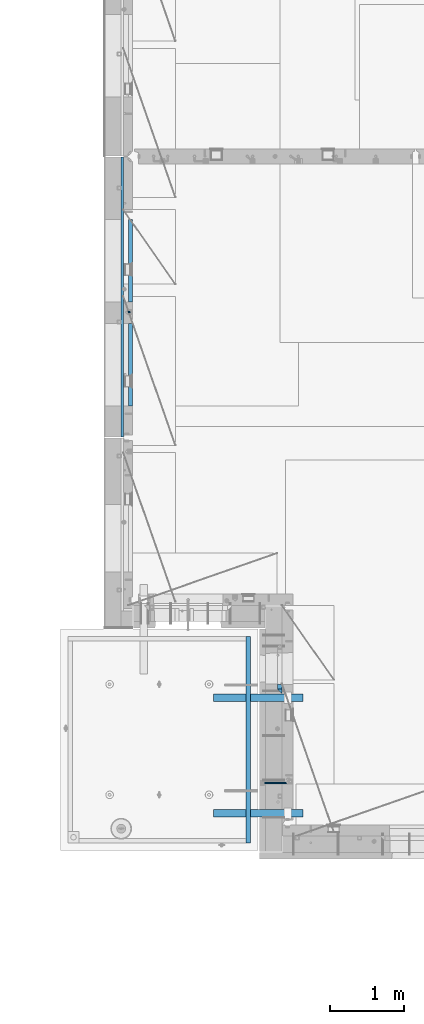
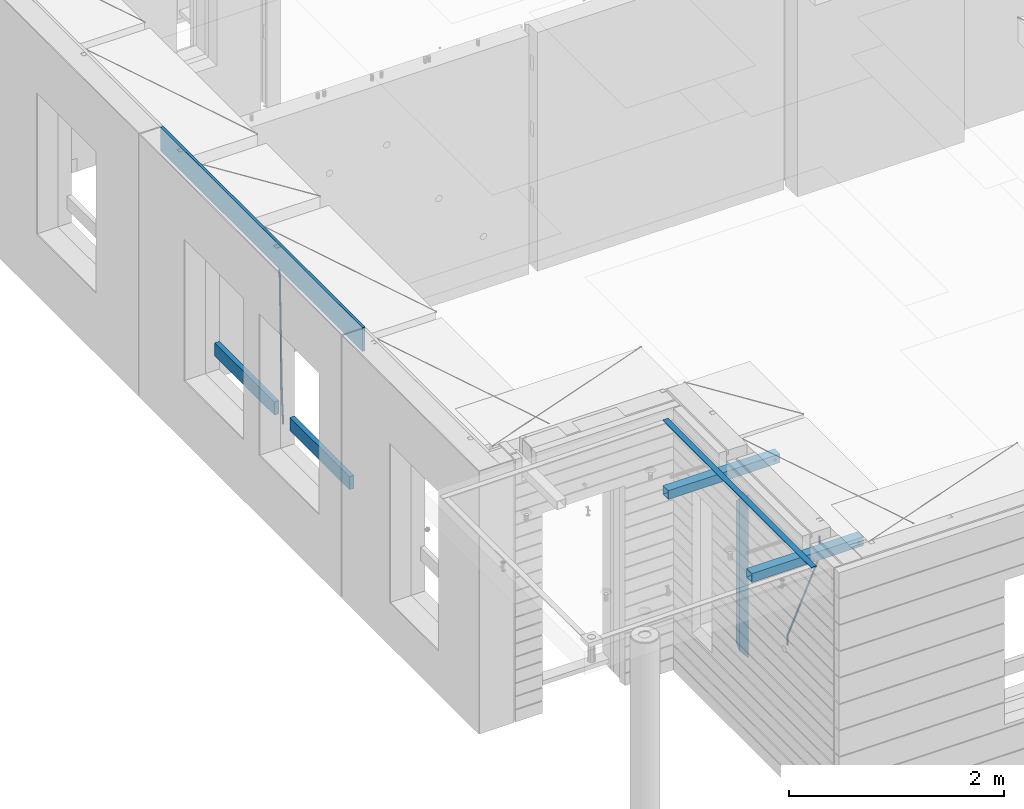
# One storey, part 93 of 350: 10 beams, 5 elements without a shape of their own.
"""IFC2X3 building model written with IfcOpenShell, lengths in millimetres."""

from ifc_helpers import new_model, si_unit, frame, origin_with_axes, place, context, subcontext, project, spatial, faceted_brep, material, type_object, element, aggregate, save


model = new_model("IFC2X3")

# Units and contexts
model_context = context("Model", 3, precision=1e-05, world=origin_with_axes())
body_context = subcontext(model_context, "Body", "Model", "MODEL_VIEW")
ifc_project = project(units=[si_unit("LENGTHUNIT", "METRE", prefix="MILLI"), si_unit("AREAUNIT", "SQUARE_METRE"), si_unit("VOLUMEUNIT", "CUBIC_METRE"), si_unit("MASSUNIT", "GRAM", prefix="KILO"), si_unit("TIMEUNIT", "SECOND"), si_unit("PLANEANGLEUNIT", "RADIAN"), si_unit("SOLIDANGLEUNIT", "STERADIAN"), si_unit("THERMODYNAMICTEMPERATUREUNIT", "DEGREE_CELSIUS"), si_unit("LUMINOUSINTENSITYUNIT", "LUMEN")], contexts=[model_context])

# Site, building, storey
site_placement = place(None, origin_with_axes())
site = spatial("IfcSite", under=ifc_project, at=site_placement, CompositionType="ELEMENT")
building_placement = place(site_placement, origin_with_axes())
building = spatial("IfcBuilding", under=site, at=building_placement, CompositionType="ELEMENT")
storey_placement = place(building_placement, origin_with_axes())
storey = spatial("IfcBuildingStorey", under=building, at=storey_placement, Name="2", CompositionType="ELEMENT", Elevation=0.0)

# Assembly, beam
assembly_1_placement = place(storey_placement, origin_with_axes())
assembly_1 = element("IfcElementAssembly", 1, at=assembly_1_placement, inside=storey, AssemblyPlace="NOTDEFINED", PredefinedType="REINFORCEMENT_UNIT")
ifc_material_1 = material()
beam_type_1 = type_object("IfcBeamType", Name="D20", PredefinedType="NOTDEFINED")
beam_1_placement = place(assembly_1_placement, frame((7964.99984877319, 14888.5021362169, 85590.0), z_axis=(-0.999642804636942, -0.000205726999925762, -0.0267249099902983), x_axis=(-0.0267249099948371, 4.30000201934385e-08, 0.999642825806181)))
beam_1 = element("IfcBeam", 2, at=beam_1_placement, type_object=beam_type_1, material=ifc_material_1, Name="JM20", ObjectType="D20", context=body_context, shape_type="Brep", body=[
    faceted_brep([(0.0, -10.0, 0.0), (-4.19531716033816e-08, -7.07106781186667, -7.07106781187031), (60.4266690400545, -7.0710677960451, -7.07106780570757), (60.4266690441291, -9.99999998418934, 6.15546014159918e-09), (0.0, 0.0, -10.0), (60.426669036824, 1.58106558956206e-08, -9.99999999384454), (4.196772351861e-08, 7.07106781186303, -7.07106781186667), (60.4266690363438, 7.07106782768096, -7.07106780570757), (0.0, 10.0, 0.0), (60.4266690388904, 10.0000000158179, 6.15182216279209e-09), (4.196772351861e-08, 7.07106781185939, 7.07106781185939), (60.4266690429649, 7.07106782768096, 7.07106781802577), (0.0, 0.0, 10.0), (60.4266690461809, 1.58179318532348e-08, 10.0000000061555), (-4.19531716033816e-08, -7.07106781187031, 7.07106781185939), (60.4266690466611, -7.07106779605238, 7.07106781802213), (61.0378400410118, -7.07106779588503, -7.07106780564936), (60.991799419251, -9.99999998403655, 6.21366780251265e-09), (61.0569027789461, 1.5985278878361e-08, -9.99999999378269), (61.0378209396877, 7.07106782784831, -7.07106780564936), (60.9917724058905, 10.0000000159635, 6.21366780251265e-09), (60.9457317841297, 7.07106782781193, 7.0710678180767), (60.9266690461809, 1.59488990902901e-08, 10.0000000062028), (60.9457508854539, -7.07106779591413, 7.0710678180767), (61.6489592143771, -7.07106614513759, -7.06310863441468), (61.5568818710308, -9.9999984576425, 0.00735959856683621), (61.6870830769039, 1.71821739058942e-06, -9.99179257185824), (61.6489210170112, 7.07106947854481, -7.06310888312146), (61.556827851804, 10.0000015422847, 0.00735924683976918), (61.4647505084577, 7.07106922979438, 7.07782747982128), (61.4266266459163, 1.36643211590126e-06, 10.0065114172685), (61.464788705809, -7.07106639389531, 7.07782772852806), (176.543135720174, -7.07075579406956, -5.56673531796696), (176.451058376813, -9.99968810657447, 1.50373291501455), (176.581259582701, 0.000312069292704109, -8.49541925541052), (176.543097522794, 7.07137982961285, -5.56673556667374), (176.451004357587, 10.00031189336, 1.50373256329476), (176.35892701424, 7.07137958085514, 8.57420079627263), (176.320803151699, 0.000311717507429421, 11.5028847337162), (176.358965211621, -7.07075604281999, 8.57420104497578), (177.098753836006, -7.07075429323595, -5.55949898843028), (176.98362511232, -9.99968666800123, 1.510669025065), (177.146421932586, 0.000313595905026887, -8.48805862247536), (177.098706077581, 7.07138133041735, -5.55949936166144), (176.983557571715, 10.0003133318824, 1.51066849724157), (176.868428848029, 7.07138095712435, 8.58083651073321), (176.820760751449, 0.000313067976094317, 11.5093961447819), (176.868476606425, -7.07075466652896, 8.58083688396073), (177.654312950661, -7.07075204110879, -5.54863964998367), (177.516135294456, -9.99968450931192, 1.52107783331303), (177.711524267797, 0.000315886711177882, -8.47701274570863), (177.654255632195, 7.07138358250813, -5.54864021007961), (177.516054233929, 10.0003154905207, 1.5210770412159), (177.377876577739, 7.0713830223176, 8.59079452451624), (177.320665260588, 0.000315094497636892, 11.5191676202448), (177.377933896176, -7.07075260129932, 8.59079508461218), (299.461778333818, -7.07025827596954, -3.16770791544877), (299.323600677439, -9.99919074416357, 3.90200956798253), (299.518989651391, 0.000809651852250681, -6.09608101123195), (299.46172101624, 7.07187734764193, -3.16770847554471), (299.323519618119, 10.0008092556727, 3.90200877589086), (299.18534196174, 7.07187678747687, 10.971726259324), (299.128130644167, 0.000808859655080596, 13.9000993551072), (299.185399279333, -7.07025883613824, 10.9717268194163), (300.005099199436, -7.07025607348805, -3.15708779472698), (299.971788958996, -9.99918809853989, 3.91467979818117), (300.018894160545, 0.00081167833377549, -6.08630953626562), (300.005085253739, 7.07187955030167, -3.15708750704471), (299.971753863239, 10.0008119014747, 3.91467990454839), (299.93844362146, 7.0718798403559, 10.9864468987271), (299.924648660366, 0.000812088532256894, 13.9156686402657), (299.938457567187, -7.07025578343564, 10.9864466110448), (300.548496018673, -7.07025720445017, -3.16258750978159), (300.620052478174, -9.9991894658433, 3.90811820064846), (300.518868553889, 0.000810637746326393, -6.09136977328126), (300.548525450897, 7.07187841925042, -3.16258766112878), (300.620094101629, 10.000810534113, 3.90811798661343), (300.69165056113, 7.07187827271991, 10.9788236970453), (300.721278025885, 0.000810430521596572, 13.907605960545), (300.691621128892, -7.07025735098068, 10.9788238483907), (1693.63216510082, -7.07315660432141, -17.2619766794614), (1693.70372156033, -10.0020888657109, -10.1912709690314), (1693.60253763606, -0.00208876212127507, -20.1907589429611), (1693.63219453306, 7.068979019381, -17.2619768308086), (1693.7037631838, 9.9979111342418, -10.1912711830664), (1693.77531964328, 7.06897887284867, -3.12056547263455), (1693.80494710806, -0.00208896934782388, -0.191783209134883), (1693.77529021105, -7.0731567508501, -3.12056532128736), (1694.29779868275, -7.07315798969103, -17.2687135518572), (1694.26743251897, -10.0020900389554, -10.1969762833342), (1694.34857500881, -0.00209031483609579, -20.1983095815103), (1694.39001741401, 7.06897744213711, -17.2696467503938), (1694.39784949942, 9.99790968965317, -10.1982960253627), (1694.36748333565, 7.06897764038877, -3.12655875683777), (1694.3167070096, -0.00209003446616407, -0.196962727188293), (1694.2752646044, -7.07315779143937, -3.125625558303), (1694.96335083364, -7.08183692566672, -17.2598557114488), (1694.83107451542, -10.0094400457037, -10.1894747662172), (1695.09452111425, -0.0118176043979474, -20.1883817771341), (1695.14774758583, 7.05909648594388, -17.259562111758), (1695.09185090323, 9.98885976961174, -10.1890595535533), (1694.95957458501, 7.0612566495729, -3.11867860832172), (1694.82840430441, -0.00876267169223865, -0.190152542638316), (1694.77517783281, -7.07967676203589, -3.11897220801256), (1716.74088258609, -7.36582038739652, -16.9700183177756), (1716.60860626785, -10.2934235074299, -9.8996373725422), (1716.87205286669, -0.295801066125932, -19.898544383459), (1716.92527933829, 6.77511302421226, -16.9697247180848), (1716.86938265568, 9.70487630788193, -9.89922215988008), (1716.73710633747, 6.77727318784673, -2.82884121464849), (1716.60593605686, -0.292746133423861, 0.0996848510367272), (1716.55270958526, -7.36366022376751, -2.82913481433934), (1717.37632925155, -7.37410674169405, -16.9615611515819), (1717.2686961548, -10.302031214369, -9.89085222946233), (1717.45037731848, -0.30334253509136, -19.8908474573927), (1717.44746400231, 6.76830362954752, -16.96277495703), (1717.36929588411, 9.6983573372836, -9.89256880959147), (1717.26166278738, 6.77043286460685, -2.82185988747187), (1717.18761472043, -0.300331341994024, 0.107426418340765), (1717.1905280366, -7.3719775066329, -2.82064608202199), (1718.0118297398, -7.37223067542982, -16.9532990407679), (1717.92884180055, -10.3000626540106, -9.8822625771154), (1718.02875100763, -0.301644694996867, -19.8833453418993), (1717.96969335481, 6.76984191386691, -16.9560200956876), (1717.86925195342, 9.69984820183527, -9.88611072988533), (1717.78626401415, 6.77201622325447, -2.81507426623284), (1717.76934274634, -0.298569757178484, 0.114972034898528), (1717.82840039914, -7.37005636604226, -2.81235321131317), (1818.03261514839, -7.07396855575644, -15.6559248891263), (1817.94962720915, -10.0018005343409, -8.58488842547376), (1818.04953641623, -0.00338257532712305, -18.5859711902594), (1817.99047876342, 7.06810403353848, -15.6586459440477), (1817.89003736203, 9.99811032150683, -8.58873657824552), (1817.80704942276, 7.07027834292421, -1.51770011459121), (1817.79012815493, -0.00030763750692131, 1.41234618654016), (1817.84918580775, -7.07179424637252, -1.51497905967153)], [[[0, 1, 2, 3]], [[1, 4, 5, 2]], [[4, 6, 7, 5]], [[6, 8, 9, 7]], [[8, 10, 11, 9]], [[10, 12, 13, 11]], [[12, 14, 15, 13]], [[14, 0, 3, 15]], [[14, 12, 10, 8, 6, 4, 1, 0]], [[3, 2, 16, 17]], [[2, 5, 18, 16]], [[5, 7, 19, 18]], [[7, 9, 20, 19]], [[9, 11, 21, 20]], [[11, 13, 22, 21]], [[13, 15, 23, 22]], [[15, 3, 17, 23]], [[17, 16, 24, 25]], [[16, 18, 26, 24]], [[18, 19, 27, 26]], [[19, 20, 28, 27]], [[20, 21, 29, 28]], [[21, 22, 30, 29]], [[22, 23, 31, 30]], [[23, 17, 25, 31]], [[25, 24, 32, 33]], [[24, 26, 34, 32]], [[26, 27, 35, 34]], [[27, 28, 36, 35]], [[28, 29, 37, 36]], [[29, 30, 38, 37]], [[30, 31, 39, 38]], [[31, 25, 33, 39]], [[33, 32, 40, 41]], [[32, 34, 42, 40]], [[34, 35, 43, 42]], [[35, 36, 44, 43]], [[36, 37, 45, 44]], [[37, 38, 46, 45]], [[38, 39, 47, 46]], [[39, 33, 41, 47]], [[41, 40, 48, 49]], [[40, 42, 50, 48]], [[42, 43, 51, 50]], [[43, 44, 52, 51]], [[44, 45, 53, 52]], [[45, 46, 54, 53]], [[46, 47, 55, 54]], [[47, 41, 49, 55]], [[49, 48, 56, 57]], [[48, 50, 58, 56]], [[50, 51, 59, 58]], [[51, 52, 60, 59]], [[52, 53, 61, 60]], [[53, 54, 62, 61]], [[54, 55, 63, 62]], [[55, 49, 57, 63]], [[57, 56, 64, 65]], [[56, 58, 66, 64]], [[58, 59, 67, 66]], [[59, 60, 68, 67]], [[60, 61, 69, 68]], [[61, 62, 70, 69]], [[62, 63, 71, 70]], [[63, 57, 65, 71]], [[65, 64, 72, 73]], [[64, 66, 74, 72]], [[66, 67, 75, 74]], [[67, 68, 76, 75]], [[68, 69, 77, 76]], [[69, 70, 78, 77]], [[70, 71, 79, 78]], [[71, 65, 73, 79]], [[73, 72, 80, 81]], [[72, 74, 82, 80]], [[74, 75, 83, 82]], [[75, 76, 84, 83]], [[76, 77, 85, 84]], [[77, 78, 86, 85]], [[78, 79, 87, 86]], [[79, 73, 81, 87]], [[81, 80, 88, 89]], [[80, 82, 90, 88]], [[82, 83, 91, 90]], [[83, 84, 92, 91]], [[84, 85, 93, 92]], [[85, 86, 94, 93]], [[86, 87, 95, 94]], [[87, 81, 89, 95]], [[89, 88, 96, 97]], [[88, 90, 98, 96]], [[90, 91, 99, 98]], [[91, 92, 100, 99]], [[92, 93, 101, 100]], [[93, 94, 102, 101]], [[94, 95, 103, 102]], [[95, 89, 97, 103]], [[97, 96, 104, 105]], [[96, 98, 106, 104]], [[98, 99, 107, 106]], [[99, 100, 108, 107]], [[100, 101, 109, 108]], [[101, 102, 110, 109]], [[102, 103, 111, 110]], [[103, 97, 105, 111]], [[105, 104, 112, 113]], [[104, 106, 114, 112]], [[106, 107, 115, 114]], [[107, 108, 116, 115]], [[108, 109, 117, 116]], [[109, 110, 118, 117]], [[110, 111, 119, 118]], [[111, 105, 113, 119]], [[113, 112, 120, 121]], [[112, 114, 122, 120]], [[114, 115, 123, 122]], [[115, 116, 124, 123]], [[116, 117, 125, 124]], [[117, 118, 126, 125]], [[118, 119, 127, 126]], [[119, 113, 121, 127]], [[121, 120, 128, 129]], [[120, 122, 130, 128]], [[122, 123, 131, 130]], [[123, 124, 132, 131]], [[124, 125, 133, 132]], [[125, 126, 134, 133]], [[126, 127, 135, 134]], [[127, 121, 129, 135]], [[130, 131, 132, 133, 134, 135, 129, 128]]]),
])

assembly_2_placement = place(storey_placement, origin_with_axes())
assembly_2 = element("IfcElementAssembly", 3, at=assembly_2_placement, inside=storey, AssemblyPlace="NOTDEFINED", PredefinedType="REINFORCEMENT_UNIT")
beam_2_placement = place(assembly_2_placement, frame((10084.9999999647, 8564.98166687309, 87407.5), z_axis=(-0.999999913638316, 0.000415599999849952, 0.0), x_axis=(0.0, 0.000121133999959918, -0.999999992663277)))
beam_2 = element("IfcBeam", 4, at=beam_2_placement, type_object=beam_type_1, material=ifc_material_1, Name="JM20", ObjectType="D20", context=body_context, shape_type="Brep", body=[
    faceted_brep([(-0.00060564729210455, -9.99999998165731, 0.0), (-0.000428079845733009, -7.07106779890455, -7.07106781186667), (119.575515501536, -7.07830994756296, -7.07106481604933), (119.575337932896, -10.0072421307195, -3.43332612828817e-06), (0.0, 0.0, -10.0), (119.575943836026, -0.00724214867295814, -9.99999700418266), (0.00042843479604926, 7.07106779888636, -7.07106781186303), (119.57637202373, 7.06382565022977, -7.07106481604933), (0.00060564729210455, 9.99999998166459, 3.63797880709171e-12), (119.576549238118, 9.99275783300072, 2.99581552098971e-06), (0.000428079845733009, 7.07106779890819, 7.07106781186667), (119.576371669405, 7.06382565024978, 7.07107080768037), (0.0, 0.0, 10.0), (119.57594333493, -0.00724214864203532, 10.0000029958155), (-0.000428434810601175, -7.07106779888272, 7.07106781186667), (119.575515147211, -7.07830994754295, 7.07107080768037), (123.007405723343, -7.07815237794966, -6.96784054723321), (122.582805401355, -10.007113663476, 0.0904711304865486), (123.182426022089, -0.00707257534122618, -9.89150983141735), (123.005342715085, 7.06398309518409, -6.96790640923791), (122.579888801934, 9.9928861221324, 0.0903624855927774), (122.155289414804, 7.06392483519267, 7.14865866135005), (121.980269116029, -0.00715496741395327, 10.0723279455269), (122.157352422975, -7.0782106379429, 7.14872452334748), (237.078231779073, -7.06149109115177, -0.0988580894754705), (236.653632119254, -9.99044140063779, 6.95944262285229), (237.253252738476, 0.00958416329558531, -3.02253833409122), (237.076170091008, 7.08064438202746, -0.0989458723961434), (236.650716449905, 10.0095583892689, 6.95931848240434), (236.226116787962, 7.08060808260052, 14.0176191980772), (236.051095828545, 0.00953282815316925, 16.941299442693), (236.228178476013, -7.0615273905787, 14.0177069809979), (256.716784942022, -7.05713112583726, 4.66796457641431), (253.8595186116, -9.98662150758355, 11.1357894837274), (257.898622726789, 0.0141676527291565, 1.98866675801037), (256.712727422928, 7.08500390428708, 4.66739235003661), (253.853780415884, 10.0133776500024, 11.1349802305504), (250.996514088198, 7.08388726532212, 17.6028051349822), (249.814676303416, 0.0125884867593413, 20.2821029533789), (251.000571607292, -7.05824776480404, 17.6033773613526), (1009.8418691523, -6.8275857616245, 337.477127600083), (1006.98460282487, -9.75707614622661, 343.94495250464), (1011.02370693708, 0.243713016892798, 334.797829781568), (1009.83781163342, 7.31454926845799, 337.476555373547), (1006.97886462661, 10.2429230142297, 343.944143254112), (1004.1215982992, 7.31343262962582, 350.411968158671), (1002.9397605144, 0.24213385110852, 353.091265977184), (1004.12565581808, -6.82870240045668, 350.412540385207), (1010.86419861369, -6.82727416533089, 337.928899317039), (1009.37206741578, -9.75634846973117, 344.999983214544), (1011.48104282112, 0.24385240851916, 334.999928444824), (1010.8612610672, 7.31486120611044, 337.928822011047), (1009.36791309767, 10.2436511734759, 344.99987388736), (1007.87578189977, 7.31457686907379, 352.070957784867), (1007.25893769236, 0.243450295225557, 354.999928657082), (1007.87871944626, -6.8275585023639, 352.071035090858), (1011.98189950881, -6.82713877372771, 337.928899260769), (1011.98225465103, -9.75603228725959, 344.999983083137), (1011.98104281745, 0.243912975529383, 334.999928419653), (1011.98018641509, 7.31499674603583, 337.928821954716), (1011.97983197065, 10.2439675657079, 344.999873755865), (1011.98018711284, 7.31507405217599, 352.070957578235), (1011.98104380422, 0.244022302918893, 354.999928419351), (1011.98190020656, -6.82706146758574, 352.071034884289), (1117.50085144035, -6.81435683895143, 337.928893948503), (1117.50120658254, -9.7432503524833, 344.999977770873), (1117.49999474897, 0.256694910305669, 334.999923107387), (1117.49913834663, 7.32777868081212, 337.92881664245), (1117.49878390216, 10.2567495004841, 344.9998684436), (1117.49913904438, 7.32785598695227, 352.070952265971), (1117.49999573575, 0.256804237695178, 354.999923107087), (1117.5008521381, -6.81427953280945, 352.071029572024)], [[[0, 1, 2, 3]], [[1, 4, 5, 2]], [[4, 6, 7, 5]], [[6, 8, 9, 7]], [[8, 10, 11, 9]], [[10, 12, 13, 11]], [[12, 14, 15, 13]], [[14, 0, 3, 15]], [[14, 12, 10, 8, 6, 4, 1, 0]], [[3, 2, 16, 17]], [[2, 5, 18, 16]], [[5, 7, 19, 18]], [[7, 9, 20, 19]], [[9, 11, 21, 20]], [[11, 13, 22, 21]], [[13, 15, 23, 22]], [[15, 3, 17, 23]], [[17, 16, 24, 25]], [[16, 18, 26, 24]], [[18, 19, 27, 26]], [[19, 20, 28, 27]], [[20, 21, 29, 28]], [[21, 22, 30, 29]], [[22, 23, 31, 30]], [[23, 17, 25, 31]], [[25, 24, 32, 33]], [[24, 26, 34, 32]], [[26, 27, 35, 34]], [[27, 28, 36, 35]], [[28, 29, 37, 36]], [[29, 30, 38, 37]], [[30, 31, 39, 38]], [[31, 25, 33, 39]], [[33, 32, 40, 41]], [[32, 34, 42, 40]], [[34, 35, 43, 42]], [[35, 36, 44, 43]], [[36, 37, 45, 44]], [[37, 38, 46, 45]], [[38, 39, 47, 46]], [[39, 33, 41, 47]], [[41, 40, 48, 49]], [[40, 42, 50, 48]], [[42, 43, 51, 50]], [[43, 44, 52, 51]], [[44, 45, 53, 52]], [[45, 46, 54, 53]], [[46, 47, 55, 54]], [[47, 41, 49, 55]], [[49, 48, 56, 57]], [[48, 50, 58, 56]], [[50, 51, 59, 58]], [[51, 52, 60, 59]], [[52, 53, 61, 60]], [[53, 54, 62, 61]], [[54, 55, 63, 62]], [[55, 49, 57, 63]], [[57, 56, 64, 65]], [[56, 58, 66, 64]], [[58, 59, 67, 66]], [[59, 60, 68, 67]], [[60, 61, 69, 68]], [[61, 62, 70, 69]], [[62, 63, 71, 70]], [[63, 57, 65, 71]], [[66, 67, 68, 69, 70, 71, 65, 64]]]),
])

# Beam
ifc_material_2 = material(Name="TIMBER/T24")
beam_type_2 = type_object("IfcBeamType", PredefinedType="NOTDEFINED")
beam_3_placement = place(assembly_1_placement, frame((7975.00000026382, 14735.0004107749, 85685.0), z_axis=(0.0, 0.0, 1.0), x_axis=(0.0, -1.0, 0.0)))
beam_3 = element("IfcBeam", 5, at=beam_3_placement, type_object=beam_type_2, material=ifc_material_2, context=body_context, shape_type="Brep", body=[
    faceted_brep([(-3.63797880709171e-12, 24.9999999999964, -75.0), (-3.63797880709171e-12, 24.9999999999964, 75.0), (1110.0, 24.9999999999964, 75.0), (1110.0, 24.9999999999964, -75.0), (0.0, -25.0000000000073, 75.0), (1110.0, -25.0000000000073, 75.0), (0.0, -25.0000000000073, -75.0), (1110.0, -25.0000000000073, -75.0)], [[[0, 1, 2, 3]], [[1, 4, 5, 2]], [[4, 6, 7, 5]], [[6, 0, 3, 7]], [[5, 7, 3, 2]], [[6, 4, 1, 0]]]),
])

beam_4_placement = place(assembly_1_placement, frame((7975.00000026382, 16134.5170325064, 85685.0), z_axis=(0.0, 0.0, 1.0), x_axis=(0.0, -1.0, 0.0)))
beam_4 = element("IfcBeam", 6, at=beam_4_placement, type_object=beam_type_2, material=ifc_material_2, context=body_context, shape_type="Brep", body=[
    faceted_brep([(-3.63797880709171e-12, 24.9999999999964, -75.0), (-3.63797880709171e-12, 24.9999999999964, 75.0), (1109.51662173163, 25.0, 75.0), (1109.51662173163, 25.0, -75.0), (0.0, -25.0000000000073, 75.0), (1109.51662173163, -25.0, 75.0), (0.0, -25.0000000000073, -75.0), (1109.51662173163, -25.0, -75.0)], [[[0, 1, 2, 3]], [[1, 4, 5, 2]], [[4, 6, 7, 5]], [[6, 0, 3, 7]], [[5, 7, 3, 2]], [[6, 4, 1, 0]]]),
])

# Assemblies, beams
assembly_3_placement = place(storey_placement, origin_with_axes())
assembly_3 = element("IfcElementAssembly", 7, at=assembly_3_placement, inside=storey, AssemblyPlace="NOTDEFINED", PredefinedType="REINFORCEMENT_UNIT")
assembly_4_placement = place(assembly_3_placement, origin_with_axes())
assembly_4 = element("IfcElementAssembly", 8, at=assembly_4_placement, AssemblyPlace="NOTDEFINED", PredefinedType="NOTDEFINED")
ifc_material_3 = material(Name="Undefined/350")
beam_type_3 = type_object("IfcBeamType", Name="100X100X5", PredefinedType="NOTDEFINED")
beam_5_placement = place(assembly_4_placement, frame((9089.99655739692, 9710.00014320107, 87555.0), z_axis=(0.0, 0.0, 1.0), x_axis=(0.999999999752625, -2.22429999942101e-05, 0.0)))
beam_5 = element("IfcBeam", 9, at=beam_5_placement, type_object=beam_type_3, material=ifc_material_3, ObjectType="100X100X5", context=body_context, shape_type="Brep", body=[
    faceted_brep([(1156.2510802317, 44.9999999999982, 10.8253175473074), (1156.25107855315, 50.0256005946221, 10.8253175473074), (1160.82639610046, 50.0256021227788, 6.25), (1160.82639777901, 44.9999999999982, 6.25), (1150.00108023171, 44.9999999999982, 12.5), (1150.00107855316, 50.0255985071226, 12.5), (1143.75108023171, 44.9999999999982, 10.8253175473074), (1143.75107855316, 50.0255964196231, 10.8253175473074), (1139.1757626844, 44.9999999999982, 6.25), (1139.17576100585, 50.0255948914664, 6.25), (1137.5010802317, 44.9999999999982, 0.0), (1137.50107855316, 50.0255943321226, 0.0), (1139.1757626844, 44.9999999999982, -6.25), (1139.17576100585, 50.0255948914664, -6.25), (1143.75108023171, 44.9999999999982, -10.8253175473074), (1143.75107855316, 50.0255964196231, -10.8253175473074), (1150.00108023171, 44.9999999999982, -12.5), (1150.00107855316, 50.0255985071226, -12.5), (1156.2510802317, 44.9999999999982, -10.8253175473074), (1156.25107855315, 50.0256005946221, -10.8253175473074), (1160.82639777901, 44.9999999999982, -6.25), (1160.82639610046, 50.0256021227788, -6.25), (1162.50108023171, 44.9999999999982, 0.0), (1162.50107855316, 50.0256026821226, 0.0), (1156.25111195316, -49.9743994042774, 10.8253175473074), (1156.25111029171, -44.9999999999991, 10.8253175473074), (1160.82642783901, -44.9999999999991, 6.25), (1160.82642950046, -49.9743978761207, 6.25), (1150.00111195316, -49.9744014917787, 12.5), (1150.00111029171, -44.9999999999991, 12.5), (1143.75111195316, -49.9744035792783, 10.8253175473074), (1143.75111029171, -44.9999999999991, 10.8253175473074), (1139.17579440585, -49.9744051074349, 6.25), (1139.1757927444, -44.9999999999991, 6.25), (1137.50111195316, -49.9744056667778, 0.0), (1137.50111029171, -44.9999999999991, 0.0), (1139.17579440585, -49.9744051074349, -6.25), (1139.1757927444, -44.9999999999991, -6.25), (1143.75111195316, -49.9744035792783, -10.8253175473074), (1143.75111029171, -44.9999999999991, -10.8253175473074), (1150.00111195316, -49.9744014917787, -12.5), (1150.00111029171, -44.9999999999991, -12.5), (1156.25111195316, -49.9743994042774, -10.8253175473074), (1156.25111029171, -44.9999999999991, -10.8253175473074), (1160.82642950046, -49.9743978761207, -6.25), (1160.82642783901, -44.9999999999991, -6.25), (1162.50111195316, -49.9743973167779, 0.0), (1162.50111029171, -44.9999999999991, 0.0), (1.81898940354586e-12, -50.0000000000009, -50.0), (1.81898940354586e-12, 49.9999999999991, -50.0), (1200.00449189278, 49.9999999999982, -50.0), (1200.00449189278, -50.0000000000009, -50.0), (1.81898940354586e-12, 49.9999999999991, 50.0), (1.81898940354586e-12, -50.0000000000009, 50.0), (1200.00449189278, -50.0000000000009, 50.0), (1200.00449189278, 49.9999999999982, 50.0), (0.0, 44.9999999999991, 45.0), (1.81898940354586e-12, -45.0000000000009, 45.0), (1.81898940354586e-12, -45.0000000000009, -45.0), (0.0, 44.9999999999991, -45.0), (1200.00449189278, 44.9999999999982, -45.0), (1200.00449189278, 44.9999999999982, 45.0), (1200.00449189278, -45.0000000000009, 45.0), (1200.00449189278, -45.0000000000009, -45.0)], [[[0, 1, 2, 3]], [[4, 5, 1, 0]], [[6, 7, 5, 4]], [[8, 9, 7, 6]], [[10, 11, 9, 8]], [[12, 13, 11, 10]], [[14, 15, 13, 12]], [[16, 17, 15, 14]], [[18, 19, 17, 16]], [[20, 21, 19, 18]], [[22, 23, 21, 20]], [[3, 2, 23, 22]], [[24, 25, 26, 27]], [[28, 29, 25, 24]], [[30, 31, 29, 28]], [[32, 33, 31, 30]], [[34, 35, 33, 32]], [[36, 37, 35, 34]], [[38, 39, 37, 36]], [[40, 41, 39, 38]], [[42, 43, 41, 40]], [[44, 45, 43, 42]], [[46, 47, 45, 44]], [[27, 26, 47, 46]], [[48, 49, 50, 51]], [[52, 53, 54, 55]], [[49, 52, 55, 50], [1, 5, 7, 9, 11, 13, 15, 17, 19, 21, 23, 2]], [[48, 53, 52, 49], [56, 57, 58, 59]], [[56, 59, 60, 61], [18, 16, 14, 12, 10, 8, 6, 4, 0, 3, 22, 20]], [[57, 56, 61, 62]], [[58, 57, 62, 63], [25, 29, 31, 33, 35, 37, 39, 41, 43, 45, 47, 26]], [[59, 58, 63, 60]], [[54, 51, 50, 55], [62, 61, 60, 63]], [[53, 48, 51, 54], [42, 40, 38, 36, 34, 32, 30, 28, 24, 27, 46, 44]]]),
])
aggregate(assembly_4, [beam_5])
assembly_5_placement = place(assembly_3_placement, origin_with_axes())
assembly_5 = element("IfcElementAssembly", 10, at=assembly_5_placement, AssemblyPlace="NOTDEFINED", PredefinedType="NOTDEFINED")
beam_6_placement = place(assembly_5_placement, frame((9089.99655739692, 8155.00014320107, 87555.0), z_axis=(0.0, 0.0, 1.0), x_axis=(0.999999999752625, -2.22429999942101e-05, 0.0)))
beam_6 = element("IfcBeam", 11, at=beam_6_placement, type_object=beam_type_3, material=ifc_material_3, ObjectType="100X100X5", context=body_context, shape_type="Brep", body=[
    faceted_brep([(1156.2510802317, 44.9999999999982, 10.8253175473074), (1156.25107855315, 50.0256005946221, 10.8253175473074), (1160.82639610046, 50.0256021227788, 6.25), (1160.82639777901, 44.9999999999982, 6.25), (1150.00108023171, 44.9999999999982, 12.5), (1150.00107855316, 50.0255985071226, 12.5), (1143.75108023171, 44.9999999999982, 10.8253175473074), (1143.75107855316, 50.0255964196231, 10.8253175473074), (1139.1757626844, 44.9999999999982, 6.25), (1139.17576100585, 50.0255948914664, 6.25), (1137.5010802317, 44.9999999999982, 0.0), (1137.50107855316, 50.0255943321226, 0.0), (1139.1757626844, 44.9999999999982, -6.25), (1139.17576100585, 50.0255948914664, -6.25), (1143.75108023171, 44.9999999999982, -10.8253175473074), (1143.75107855316, 50.0255964196231, -10.8253175473074), (1150.00108023171, 44.9999999999982, -12.5), (1150.00107855316, 50.0255985071226, -12.5), (1156.2510802317, 44.9999999999982, -10.8253175473074), (1156.25107855315, 50.0256005946221, -10.8253175473074), (1160.82639777901, 44.9999999999982, -6.25), (1160.82639610046, 50.0256021227788, -6.25), (1162.50108023171, 44.9999999999982, 0.0), (1162.50107855316, 50.0256026821226, 0.0), (1156.25111195316, -49.9743994042774, 10.8253175473074), (1156.25111029171, -44.9999999999991, 10.8253175473074), (1160.82642783901, -44.9999999999991, 6.25), (1160.82642950046, -49.9743978761207, 6.25), (1150.00111195316, -49.9744014917787, 12.5), (1150.00111029171, -44.9999999999991, 12.5), (1143.75111195316, -49.9744035792783, 10.8253175473074), (1143.75111029171, -44.9999999999991, 10.8253175473074), (1139.17579440585, -49.9744051074349, 6.25), (1139.1757927444, -44.9999999999991, 6.25), (1137.50111195316, -49.9744056667778, 0.0), (1137.50111029171, -44.9999999999991, 0.0), (1139.17579440585, -49.9744051074349, -6.25), (1139.1757927444, -44.9999999999991, -6.25), (1143.75111195316, -49.9744035792783, -10.8253175473074), (1143.75111029171, -44.9999999999991, -10.8253175473074), (1150.00111195316, -49.9744014917787, -12.5), (1150.00111029171, -44.9999999999991, -12.5), (1156.25111195316, -49.9743994042774, -10.8253175473074), (1156.25111029171, -44.9999999999991, -10.8253175473074), (1160.82642950046, -49.9743978761207, -6.25), (1160.82642783901, -44.9999999999991, -6.25), (1162.50111195316, -49.9743973167779, 0.0), (1162.50111029171, -44.9999999999991, 0.0), (1.81898940354586e-12, -50.0000000000009, -50.0), (1.81898940354586e-12, 49.9999999999991, -50.0), (1200.00449189278, 49.9999999999982, -50.0), (1200.00449189278, -50.0000000000009, -50.0), (1.81898940354586e-12, 49.9999999999991, 50.0), (1.81898940354586e-12, -50.0000000000009, 50.0), (1200.00449189278, -50.0000000000009, 50.0), (1200.00449189278, 49.9999999999982, 50.0), (0.0, 44.9999999999991, 45.0), (1.81898940354586e-12, -45.0000000000009, 45.0), (1.81898940354586e-12, -45.0000000000009, -45.0), (0.0, 44.9999999999991, -45.0), (1200.00449189278, 44.9999999999982, -45.0), (1200.00449189278, 44.9999999999982, 45.0), (1200.00449189278, -45.0000000000009, 45.0), (1200.00449189278, -45.0000000000009, -45.0)], [[[0, 1, 2, 3]], [[4, 5, 1, 0]], [[6, 7, 5, 4]], [[8, 9, 7, 6]], [[10, 11, 9, 8]], [[12, 13, 11, 10]], [[14, 15, 13, 12]], [[16, 17, 15, 14]], [[18, 19, 17, 16]], [[20, 21, 19, 18]], [[22, 23, 21, 20]], [[3, 2, 23, 22]], [[24, 25, 26, 27]], [[28, 29, 25, 24]], [[30, 31, 29, 28]], [[32, 33, 31, 30]], [[34, 35, 33, 32]], [[36, 37, 35, 34]], [[38, 39, 37, 36]], [[40, 41, 39, 38]], [[42, 43, 41, 40]], [[44, 45, 43, 42]], [[46, 47, 45, 44]], [[27, 26, 47, 46]], [[48, 49, 50, 51]], [[52, 53, 54, 55]], [[49, 52, 55, 50], [1, 5, 7, 9, 11, 13, 15, 17, 19, 21, 23, 2]], [[48, 53, 52, 49], [56, 57, 58, 59]], [[56, 59, 60, 61], [18, 16, 14, 12, 10, 8, 6, 4, 0, 3, 22, 20]], [[57, 56, 61, 62]], [[58, 57, 62, 63], [25, 29, 31, 33, 35, 37, 39, 41, 43, 45, 47, 26]], [[59, 58, 63, 60]], [[54, 51, 50, 55], [62, 61, 60, 63]], [[53, 48, 51, 54], [42, 40, 38, 36, 34, 32, 30, 28, 24, 27, 46, 44]]]),
])
aggregate(assembly_5, [beam_6])
ifc_material_4 = material(Name="CONCRETE/Concrete_Undefined")
beam_type_4 = type_object("IfcBeamType", PredefinedType="NOTDEFINED")
beam_7_placement = place(assembly_3_placement, frame((9559.6242765169, 7760.00786459139, 87724.2917943147), z_axis=(-2.9999991954625e-09, -0.000129499999950134, 0.999999991614875), x_axis=(2.43220000075427e-05, 0.999999991319095, 0.000129500000041638)))
beam_7 = element("IfcBeam", 12, at=beam_7_placement, type_object=beam_type_4, material=ifc_material_4, context=body_context, shape_type="Brep", body=[
    faceted_brep([(2.5465851649642e-11, 29.9999999999982, -4.99999999998545), (-2.91038304567337e-11, 29.9999999999982, 5.0), (2770.00002322912, 29.9999999999982, 5.00000000001455), (2770.00002322912, 29.9999999999982, -4.9999999999709), (-2.5465851649642e-11, -30.0000000000018, 5.0), (2770.00002322912, -30.0000000000018, 5.0), (2.72848410531878e-11, -30.0000000000018, -4.99999999998545), (2770.00002322912, -30.0000000000018, -4.99999999998545)], [[[0, 1, 2, 3]], [[1, 4, 5, 2]], [[4, 6, 7, 5]], [[6, 0, 3, 7]], [[5, 7, 3, 2]], [[6, 4, 1, 0]]]),
])
aggregate(assembly_3, [assembly_4, assembly_5, beam_7])

# Beam
ifc_material_5 = material(Name="CONCRETE/C25/30")
beam_type_5 = type_object("IfcBeamType", PredefinedType="NOTDEFINED")
beam_8_placement = place(assembly_2_placement, frame((9980.0, 9795.00042424099, 87175.0), z_axis=(0.0, 1.0, 0.0), x_axis=(0.0, 0.0, -1.0)))
beam_8 = element("IfcBeam", 13, at=beam_8_placement, type_object=beam_type_5, material=ifc_material_5, Name="SK", context=body_context, shape_type="Brep", body=[
    faceted_brep([(60.0000000000073, 30.0, 30.0), (0.0, -30.0, -30.0), (60.0000000000073, -30.0, 30.0), (1795.00000000001, -30.0, 30.0), (1795.00000000001, 30.0, 30.0), (1855.0, -30.0, -30.0)], [[[0, 1, 2]], [[3, 4, 0, 2]], [[4, 5, 1, 0]], [[5, 3, 2, 1]], [[3, 5, 4]]]),
])

beam_type_6 = type_object("IfcBeamType", PredefinedType="NOTDEFINED")
beam_9_placement = place(assembly_2_placement, frame((9980.00000000155, 9860.00042424099, 87115.0), z_axis=(0.0, 1.0, 0.0), x_axis=(0.0, 0.0, -1.0)))
beam_9 = element("IfcBeam", 14, at=beam_9_placement, type_object=beam_type_6, material=ifc_material_5, Name="SK", context=body_context, shape_type="Brep", body=[
    faceted_brep([(0.0, -30.0, -35.0), (54.9034748914273, -30.0, 29.0540540540533), (56.2934362811066, 30.0, 30.6756756756768), (0.0, 30.0, -35.0), (1680.09652510857, -30.0, 29.0540540540533), (1678.70656371891, 30.0, 30.6756756756768), (1735.0, 30.0, -35.0), (1735.0, -30.0, -35.0)], [[[0, 1, 2, 3]], [[2, 1, 4, 5]], [[3, 2, 5, 6]], [[6, 7, 0, 3]], [[1, 0, 7, 4]], [[7, 6, 5, 4]]]),
])

aggregate(assembly_2, [beam_2, beam_8, beam_9])

beam_type_7 = type_object("IfcBeamType", Name="270X30", PredefinedType="NOTDEFINED")
beam_10_placement = place(assembly_1_placement, frame((7865.00000036742, 16969.9999989039, 87605.0), z_axis=(0.0, 0.0, 1.0), x_axis=(0.0, -1.0, 0.0)))
beam_10 = element("IfcBeam", 15, at=beam_10_placement, type_object=beam_type_7, material=ifc_material_5, ObjectType="270X30", context=body_context, shape_type="Brep", body=[
    faceted_brep([(0.0, 15.0, -135.0), (0.0, 15.0, 135.0), (3759.99957708467, 15.0, 135.0), (3759.99957708467, 15.0, -135.0), (0.0, -15.0, 135.0), (3759.99957708467, -15.0, 135.0), (0.0, -15.0, -135.0), (3759.99957708467, -15.0, -135.0)], [[[0, 1, 2, 3]], [[1, 4, 5, 2]], [[4, 6, 7, 5]], [[6, 0, 3, 7]], [[5, 7, 3, 2]], [[6, 4, 1, 0]]]),
])

aggregate(assembly_1, [beam_1, beam_3, beam_10, beam_4])

save(model, "model.ifc")
